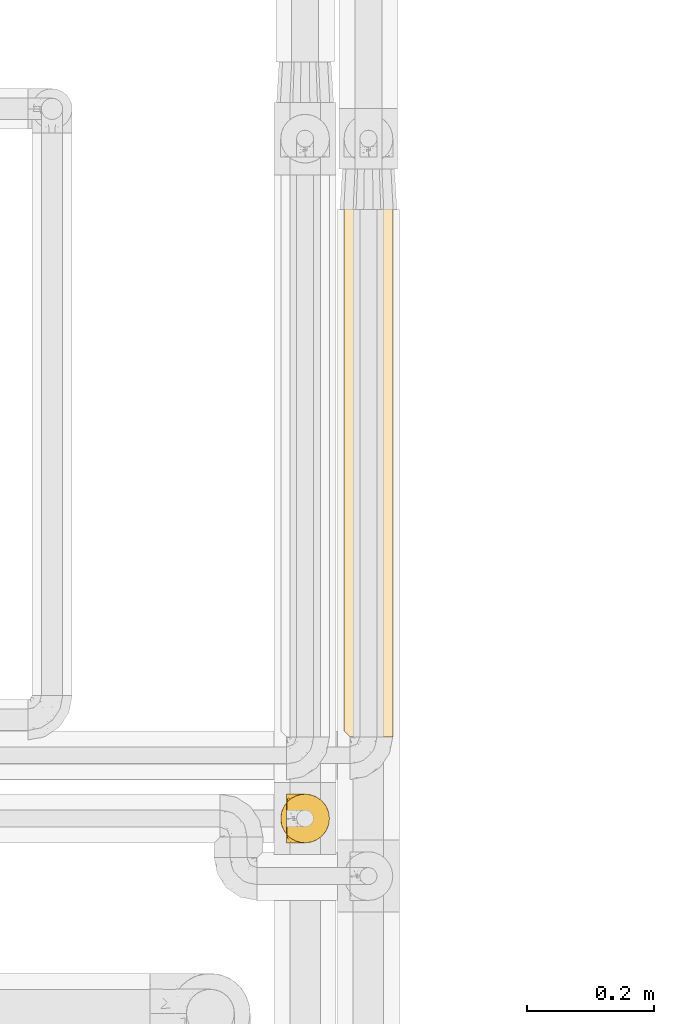
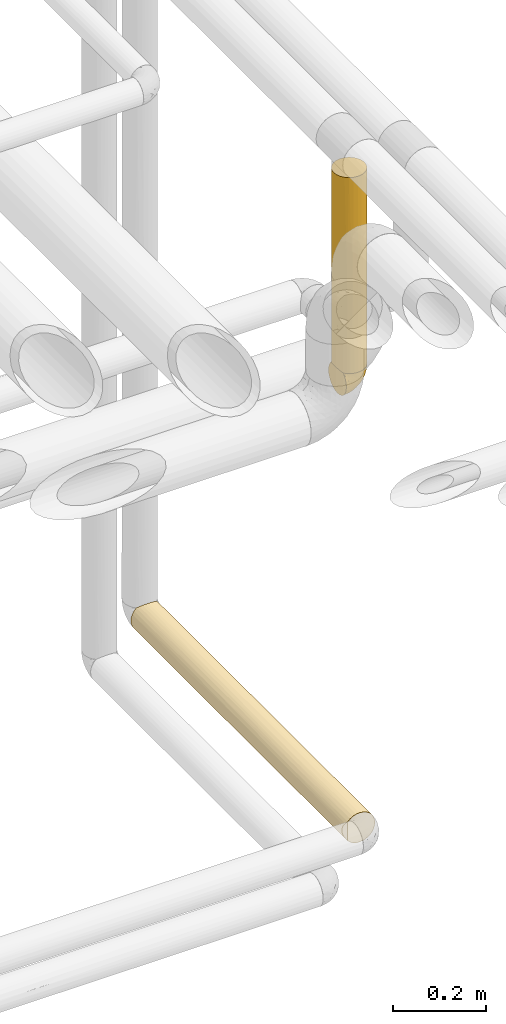
# One storey, part 498 of 827: 3 coverings.
"""IFC2X3 building model written with IfcOpenShell, lengths in millimetres."""

from ifc_helpers import new_model, entity, si_unit, converted_unit, derived_unit, direction, frame, origin, place, context, subcontext, project, spatial, faceted_brep, element, save


model = new_model("IFC2X3")

# Units and contexts
model_context = context("Model", 3, precision=0.01, world=origin(), true_north=direction((6.12303176911189e-17, 1.0)))
body_context = subcontext(model_context, "Body", "Model", "MODEL_VIEW")
ifc_project = project(units=[si_unit("LENGTHUNIT", "METRE", prefix="MILLI"), si_unit("AREAUNIT", "SQUARE_METRE"), si_unit("VOLUMEUNIT", "CUBIC_METRE"), converted_unit("PLANEANGLEUNIT", "DEGREE", entity("IfcRatioMeasure", 0.0174532925199433), si_unit("PLANEANGLEUNIT", "RADIAN"), dimensions=[0, 0, 0, 0, 0, 0, 0]), si_unit("MASSUNIT", "GRAM", prefix="KILO"), derived_unit("MASSDENSITYUNIT", [(si_unit("MASSUNIT", "GRAM", prefix="KILO"), 1), (si_unit("LENGTHUNIT", "METRE"), -3)]), derived_unit("MOMENTOFINERTIAUNIT", [(si_unit("LENGTHUNIT", "METRE"), 4)]), si_unit("TIMEUNIT", "SECOND"), si_unit("FREQUENCYUNIT", "HERTZ"), si_unit("THERMODYNAMICTEMPERATUREUNIT", "DEGREE_CELSIUS"), derived_unit("THERMALTRANSMITTANCEUNIT", [(si_unit("MASSUNIT", "GRAM", prefix="KILO"), 1), (si_unit("THERMODYNAMICTEMPERATUREUNIT", "KELVIN"), -1), (si_unit("TIMEUNIT", "SECOND"), -3)]), derived_unit("VOLUMETRICFLOWRATEUNIT", [(si_unit("LENGTHUNIT", "METRE"), 3), (si_unit("TIMEUNIT", "SECOND"), -1)]), derived_unit("MASSFLOWRATEUNIT", [(si_unit("MASSUNIT", "GRAM", prefix="KILO"), 1), (si_unit("TIMEUNIT", "SECOND"), -1)]), derived_unit("ROTATIONALFREQUENCYUNIT", [(si_unit("TIMEUNIT", "SECOND"), -1)]), si_unit("ELECTRICCURRENTUNIT", "AMPERE"), si_unit("ELECTRICVOLTAGEUNIT", "VOLT"), si_unit("POWERUNIT", "WATT"), si_unit("FORCEUNIT", "NEWTON", prefix="KILO"), si_unit("ILLUMINANCEUNIT", "LUX"), si_unit("LUMINOUSFLUXUNIT", "LUMEN"), si_unit("LUMINOUSINTENSITYUNIT", "CANDELA"), derived_unit("USERDEFINED", [(si_unit("MASSUNIT", "GRAM", prefix="KILO"), -1), (si_unit("LENGTHUNIT", "METRE"), -2), (si_unit("TIMEUNIT", "SECOND"), 3), (si_unit("LUMINOUSFLUXUNIT", "LUMEN"), 1)]), derived_unit("LINEARVELOCITYUNIT", [(si_unit("LENGTHUNIT", "METRE"), 1), (si_unit("TIMEUNIT", "SECOND"), -1)]), si_unit("PRESSUREUNIT", "PASCAL"), derived_unit("USERDEFINED", [(si_unit("LENGTHUNIT", "METRE"), -2), (si_unit("MASSUNIT", "GRAM", prefix="KILO"), 1), (si_unit("TIMEUNIT", "SECOND"), -2)]), derived_unit("LINEARFORCEUNIT", [(si_unit("MASSUNIT", "GRAM", prefix="KILO"), 1), (si_unit("LENGTHUNIT", "METRE"), 1), (si_unit("TIMEUNIT", "SECOND"), -2), (si_unit("LENGTHUNIT", "METRE"), -1)]), derived_unit("PLANARFORCEUNIT", [(si_unit("MASSUNIT", "GRAM", prefix="KILO"), 1), (si_unit("LENGTHUNIT", "METRE"), 1), (si_unit("TIMEUNIT", "SECOND"), -2), (si_unit("LENGTHUNIT", "METRE"), -2)])], contexts=[model_context])

# Site, building, storey
site_placement = place(None, origin())
site = spatial("IfcSite", under=ifc_project, at=site_placement, CompositionType="ELEMENT")
building_placement = place(site_placement, origin())
building = spatial("IfcBuilding", under=site, at=building_placement, CompositionType="ELEMENT")
storey_placement = place(building_placement, frame((0.0, 0.0, 28200.0)))
storey = spatial("IfcBuildingStorey", under=building, at=storey_placement, Name="08", CompositionType="ELEMENT", Elevation=28200.0)

# Coverings
covering_1_placement = place(storey_placement, frame((61012.64, 16339.84, 2427.5)))
element("IfcCovering", 1, at=covering_1_placement, inside=storey, Name=":ADSK_", ObjectType=":ADSK_", PredefinedType="INSULATION", context=body_context, shape_type="Brep", body=[
    faceted_brep([(77.09, 30.06, 515.24), (78.4, 40.0, 515.24), (77.09, 49.93, 515.24), (73.25, 59.2, 515.24), (67.15, 67.15, 515.24), (59.2, 73.25, 515.24), (49.93, 77.09, 515.24), (40.0, 78.4, 515.24), (30.06, 77.09, 515.24), (20.8, 73.25, 515.24), (12.84, 67.15, 515.24), (6.74, 59.2, 515.24), (2.9, 49.93, 515.24), (1.6, 40.0, 515.24), (2.9, 30.06, 515.24), (6.74, 20.8, 515.24), (12.84, 12.84, 515.24), (20.8, 6.74, 515.24), (30.06, 2.9, 515.24), (40.0, 1.6, 515.24), (49.93, 2.9, 515.24), (59.2, 6.74, 515.24), (67.15, 12.84, 515.24), (73.25, 20.8, 515.24), (77.09, 49.93, 1.6), (78.4, 40.0, 1.6), (77.09, 30.06, 1.6), (73.25, 20.8, 1.6), (67.15, 12.84, 1.6), (59.2, 6.74, 1.6), (49.93, 2.9, 1.6), (40.0, 1.6, 1.6), (31.77, 2.49, 1.6), (23.94, 5.11, 1.6), (16.85, 9.36, 1.6), (10.83, 15.02, 1.6), (10.83, 64.97, 1.6), (16.85, 70.63, 1.6), (23.94, 74.88, 1.6), (31.77, 77.5, 1.6), (40.0, 78.4, 1.6), (49.93, 77.09, 1.6), (59.2, 73.25, 1.6), (67.15, 67.15, 1.6), (73.25, 59.2, 1.6), (63.37, 9.53, 252.55), (54.69, 4.52, 258.42), (47.49, 2.33, 211.7), (75.47, 25.3, 258.42), (40.0, 1.6, 258.42), (40.0, 1.6, 217.97), (70.46, 16.62, 264.28), (77.66, 32.5, 305.13), (78.4, 40.0, 258.42), (78.4, 40.0, 298.87), (77.64, 47.56, 307.34), (75.47, 54.69, 264.28), (47.49, 77.66, 305.13), (54.69, 75.47, 258.42), (70.46, 63.37, 258.42), (63.37, 70.46, 264.28), (40.0, 78.4, 217.97), (40.0, 78.4, 258.42), (27.78, 76.4, 249.14), (16.62, 70.46, 278.77), (1.6, 40.0, 227.2), (2.96, 50.15, 252.84), (2.2, 46.76, 10.23), (5.33, 56.51, 325.54), (8.84, 62.45, 262.16), (3.98, 53.31, 8.45), (1.6, 40.0, 10.83), (6.89, 59.45, 5.54), (3.98, 26.68, 8.45), (6.89, 20.54, 5.54), (5.38, 23.38, 191.86), (8.84, 17.55, 262.16), (2.96, 29.84, 252.84), (2.2, 33.23, 10.23), (16.62, 9.53, 278.77), (27.78, 3.59, 249.14)], [[[0, 1, 2, 3, 4, 5, 6, 7, 8, 9, 10, 11, 12, 13, 14, 15, 16, 17, 18, 19, 20, 21, 22, 23]], [[24, 25, 26, 27, 28, 29, 30, 31, 32, 33, 34, 35, 36, 37, 38, 39, 40, 41, 42, 43, 44]], [[29, 28, 45]], [[20, 46, 21]], [[30, 29, 46]], [[47, 30, 46]], [[23, 48, 0]], [[47, 19, 49, 50, 31]], [[21, 45, 22]], [[30, 47, 31]], [[46, 45, 21]], [[28, 27, 51]], [[45, 46, 29]], [[52, 1, 0]], [[48, 27, 26]], [[20, 47, 46]], [[52, 25, 53, 54, 1]], [[51, 48, 23]], [[51, 27, 48]], [[22, 45, 51]], [[22, 51, 23]], [[48, 52, 0]], [[52, 26, 25]], [[51, 45, 28]], [[26, 52, 48]], [[47, 20, 19]], [[55, 24, 56]], [[41, 57, 58]], [[55, 1, 54, 53, 25]], [[56, 59, 3]], [[59, 56, 44]], [[55, 25, 24]], [[43, 59, 44]], [[59, 4, 3]], [[3, 2, 56]], [[42, 58, 60]], [[7, 57, 40, 61, 62]], [[58, 42, 41]], [[58, 5, 60]], [[43, 60, 59]], [[4, 59, 60]], [[42, 60, 43]], [[55, 56, 2]], [[5, 4, 60]], [[58, 57, 6]], [[5, 58, 6]], [[44, 56, 24]], [[57, 41, 40]], [[1, 55, 2]], [[57, 7, 6]], [[61, 39, 63]], [[38, 37, 64]], [[64, 63, 38]], [[65, 66, 67]], [[39, 61, 40]], [[63, 39, 38]], [[63, 9, 8]], [[64, 10, 9]], [[12, 11, 68]], [[69, 64, 36]], [[68, 70, 66]], [[69, 10, 64]], [[67, 66, 70]], [[11, 10, 69]], [[67, 71, 65]], [[68, 72, 70]], [[61, 63, 8]], [[68, 11, 69]], [[64, 37, 36]], [[13, 12, 66]], [[66, 65, 13]], [[63, 64, 9]], [[72, 68, 69]], [[72, 69, 36]], [[12, 68, 66]], [[8, 7, 62, 61]], [[73, 74, 75]], [[16, 15, 76]], [[35, 76, 74]], [[77, 78, 73]], [[79, 35, 34]], [[76, 75, 74]], [[65, 78, 77]], [[77, 14, 13]], [[78, 65, 71]], [[75, 15, 77]], [[65, 77, 13]], [[77, 15, 14]], [[33, 80, 79]], [[33, 32, 80]], [[15, 75, 76]], [[73, 75, 77]], [[18, 50, 49, 19]], [[32, 31, 50]], [[16, 79, 17]], [[76, 79, 16]], [[17, 79, 80]], [[50, 80, 32]], [[17, 80, 18]], [[79, 34, 33]], [[35, 79, 76]], [[50, 18, 80]], [[71, 67, 70, 72, 36, 35, 74, 73, 78]]]),
])
covering_2_placement = place(storey_placement, frame((61021.94, 16339.79, 2359.95)))
element("IfcCovering", 2, at=covering_2_placement, inside=storey, Name=":ADSK_", ObjectType=":ADSK_", PredefinedType="INSULATION", context=body_context, shape_type="Brep", body=[
    faceted_brep([(1.6, 74.68, 23.36), (1.6, 70.1, 16.07), (1.6, 64.01, 9.98), (1.6, 56.72, 5.4), (1.6, 48.6, 2.56), (1.6, 40.05, 1.6), (1.6, 31.49, 2.56), (1.6, 23.36, 5.41), (1.6, 16.07, 9.99), (1.6, 9.98, 16.08), (1.6, 5.4, 23.37), (1.6, 2.56, 31.49), (1.6, 1.6, 40.05), (1.6, 2.46, 48.15), (1.6, 5.01, 55.88), (1.6, 9.13, 62.9), (1.6, 14.62, 68.89), (1.6, 16.82, 68.89), (1.6, 18.56, 68.89), (1.6, 20.52, 68.89), (1.6, 22.49, 68.89), (1.6, 24.46, 68.89), (1.6, 26.42, 68.89), (1.6, 28.39, 68.89), (1.6, 30.36, 68.89), (1.6, 32.55, 68.89), (1.6, 34.75, 68.89), (1.6, 36.94, 68.89), (1.6, 39.13, 68.89), (1.6, 41.33, 68.89), (1.6, 43.52, 68.89), (1.6, 45.72, 68.89), (1.6, 47.91, 68.89), (1.6, 50.11, 68.89), (1.6, 52.3, 68.89), (1.6, 54.49, 68.89), (1.6, 56.69, 68.89), (1.6, 58.88, 68.89), (1.6, 61.08, 68.89), (1.6, 63.27, 68.89), (1.6, 65.47, 68.89), (1.6, 70.97, 62.89), (1.6, 75.09, 55.86), (1.6, 77.64, 48.13), (1.6, 78.5, 40.05), (1.6, 77.53, 31.49), (1.85, 14.62, 69.15), (7.85, 9.12, 69.15), (14.87, 5.0, 69.15), (22.6, 2.46, 69.15), (30.7, 1.6, 69.15), (40.65, 2.91, 69.15), (49.92, 6.75, 69.15), (57.88, 12.86, 69.15), (63.99, 20.82, 69.15), (67.84, 30.09, 69.15), (69.15, 40.05, 69.15), (67.84, 50.0, 69.15), (63.99, 59.27, 69.15), (57.88, 67.23, 69.15), (49.92, 73.34, 69.15), (40.65, 77.19, 69.15), (30.7, 78.5, 69.15), (22.6, 77.63, 69.15), (14.87, 75.09, 69.15), (7.85, 70.97, 69.15), (1.85, 65.47, 69.15), (1.85, 63.27, 69.15), (1.85, 62.29, 69.15), (1.85, 60.7, 69.15), (1.85, 59.11, 69.15), (1.85, 57.52, 69.15), (1.85, 55.93, 69.15), (1.85, 54.34, 69.15), (1.85, 52.76, 69.15), (1.85, 51.17, 69.15), (1.85, 49.58, 69.15), (1.85, 47.99, 69.15), (1.85, 46.4, 69.15), (1.85, 44.81, 69.15), (1.85, 43.22, 69.15), (1.85, 41.63, 69.15), (1.85, 40.05, 69.15), (1.85, 38.46, 69.15), (1.85, 36.87, 69.15), (1.85, 35.28, 69.15), (1.85, 33.69, 69.15), (1.85, 32.1, 69.15), (1.85, 30.51, 69.15), (1.85, 28.92, 69.15), (1.85, 27.33, 69.15), (1.85, 25.37, 69.15), (1.85, 23.4, 69.15), (1.85, 21.21, 69.15), (1.85, 19.01, 69.15), (1.85, 16.82, 69.15), (1.77, 42.32, 68.96), (1.78, 44.02, 68.97), (1.77, 47.13, 68.97), (1.77, 48.74, 68.97), (1.76, 23.57, 68.95), (1.77, 25.13, 68.96), (1.79, 61.34, 68.98), (1.78, 22.02, 68.97), (1.78, 29.72, 68.97), (1.78, 56.73, 68.98), (1.78, 55.14, 68.97), (1.78, 37.66, 68.97), (1.74, 64.12, 68.94), (1.78, 28.13, 68.98), (1.78, 26.62, 68.98), (1.77, 31.46, 68.96), (1.78, 16.16, 68.97), (1.78, 39.16, 68.98), (1.78, 50.37, 68.98), (1.77, 17.69, 68.97), (1.77, 19.17, 68.96), (1.77, 62.78, 68.97), (1.78, 58.35, 68.97), (1.78, 45.53, 68.98), (1.77, 59.91, 68.96), (1.77, 65.47, 68.97), (1.72, 65.47, 68.94), (1.77, 14.62, 68.97), (1.8, 14.62, 69.02), (1.82, 14.62, 69.08), (1.79, 20.59, 68.98), (1.78, 32.99, 68.97), (1.79, 34.48, 68.98), (1.78, 51.91, 68.97), (1.82, 65.47, 69.08), (1.8, 65.47, 69.02), (1.76, 53.48, 68.96), (1.66, 14.62, 68.92), (1.72, 14.62, 68.94), (1.78, 40.77, 68.97), (1.77, 35.97, 68.96), (9.41, 7.84, 67.02), (17.65, 3.53, 63.33), (7.41, 8.32, 64.61), (21.47, 1.6, 49.27), (15.21, 2.19, 51.4), (16.15, 1.6, 43.94), (28.75, 1.6, 61.87), (13.67, 4.57, 61.54), (12.79, 3.96, 57.95), (19.18, 2.28, 56.12), (29.16, 1.6, 63.4), (9.04, 7.69, 65.41), (7.41, 3.53, 53.1), (5.74, 8.32, 63.04), (3.72, 7.84, 61.33), (8.87, 1.6, 41.99), (26.8, 1.6, 54.6), (9.53, 4.34, 56.6), (7.34, 1.6, 41.58), (37.63, 29.63, 13.72), (17.92, 27.34, 5.82), (27.45, 40.05, 6.74), (37.01, 2.39, 58.82), (34.22, 2.43, 51.58), (45.87, 9.07, 42.09), (56.57, 16.64, 46.12), (52.31, 9.54, 55.56), (42.07, 4.52, 52.38), (44.74, 4.52, 61.54), (21.49, 7.49, 23.76), (11.02, 7.49, 20.5), (15.64, 12.85, 14.64), (26.02, 2.35, 41.77), (36.59, 22.66, 16.28), (65.49, 32.9, 49.4), (63.99, 25.33, 52.34), (15.2, 40.05, 4.3), (60.27, 16.64, 58.67), (45.25, 19.99, 25.26), (35.21, 16.37, 20.17), (22.52, 3.26, 34.7), (12.03, 3.75, 28.67), (13.32, 19.58, 8.62), (35.9, 7.5, 33.37), (33.87, 4.04, 41.35), (25.73, 13.94, 17.15), (26.34, 19.58, 12.68), (46.78, 28.21, 21.47), (59.54, 24.75, 41.11), (60.18, 31.42, 37.53), (53.93, 26.2, 30.64), (53.36, 33.36, 26.66), (49.36, 40.05, 21.38), (38.4, 40.05, 14.06), (66.44, 40.05, 55.54), (50.09, 16.14, 35.17), (41.08, 12.85, 29.04), (31.14, 10.47, 24.34), (28.19, 6.49, 29.33), (64.0, 40.05, 43.3), (56.68, 40.05, 32.34), (43.9, 75.57, 57.75), (65.46, 47.37, 49.41), (52.22, 52.91, 27.85), (37.61, 50.46, 13.7), (15.64, 67.23, 14.63), (13.31, 60.5, 8.61), (50.02, 70.55, 48.85), (59.28, 63.45, 54.13), (53.05, 62.61, 37.84), (21.48, 72.6, 23.75), (11.01, 72.6, 20.49), (12.03, 76.34, 28.66), (41.02, 59.34, 20.83), (35.39, 77.76, 55.15), (26.8, 78.5, 54.6), (28.75, 78.5, 61.87), (7.34, 78.5, 41.58), (65.81, 53.16, 57.58), (53.28, 70.55, 59.91), (59.8, 48.88, 36.94), (61.82, 54.76, 45.72), (17.91, 52.74, 5.82), (41.4, 71.93, 37.91), (40.48, 75.79, 50.18), (26.34, 60.5, 12.67), (31.68, 77.86, 49.29), (27.68, 77.64, 42.64), (16.15, 78.5, 43.94), (21.47, 78.5, 49.27), (28.05, 67.23, 19.45), (22.54, 76.82, 34.7), (8.87, 78.5, 41.99), (37.3, 77.8, 62.29), (41.07, 67.23, 29.01), (32.24, 73.2, 31.47), (47.4, 67.66, 37.18), (35.77, 75.99, 43.45), (17.65, 76.57, 63.33), (11.06, 73.21, 67.23), (8.55, 71.93, 66.07), (6.63, 71.07, 65.22), (12.77, 75.09, 61.99), (12.79, 76.13, 57.95), (7.41, 76.57, 53.09), (18.97, 77.69, 56.84), (1.66, 65.47, 68.92), (3.72, 72.26, 61.33), (5.76, 71.77, 63.06), (15.21, 77.9, 51.41), (9.52, 75.75, 56.61)], [[[0, 1, 2, 3, 4, 5, 6, 7, 8, 9, 10, 11, 12, 13, 14, 15, 16, 17, 18, 19, 20, 21, 22, 23, 24, 25, 26, 27, 28, 29, 30, 31, 32, 33, 34, 35, 36, 37, 38, 39, 40, 41, 42, 43, 44, 45]], [[46, 47, 48, 49, 50, 51, 52, 53, 54, 55, 56, 57, 58, 59, 60, 61, 62, 63, 64, 65, 66, 67, 68, 69, 70, 71, 72, 73, 74, 75, 76, 77, 78, 79, 80, 81, 82, 83, 84, 85, 86, 87, 88, 89, 90, 91, 92, 93, 94, 95]], [[96, 97, 30]], [[98, 77, 99]], [[100, 101, 21]], [[69, 68, 102]], [[20, 19, 103]], [[24, 23, 104]], [[20, 103, 100]], [[72, 105, 106]], [[84, 83, 107]], [[89, 88, 104]], [[108, 67, 66]], [[109, 110, 90]], [[111, 25, 24]], [[112, 17, 16]], [[82, 113, 83]], [[109, 23, 22]], [[114, 76, 75]], [[105, 36, 106]], [[104, 111, 24]], [[18, 115, 116]], [[97, 96, 80]], [[67, 108, 117]], [[105, 71, 118]], [[31, 97, 119]], [[102, 120, 69]], [[108, 121, 122]], [[112, 95, 115]], [[17, 115, 18]], [[94, 116, 115]], [[117, 68, 67]], [[38, 117, 39]], [[112, 123, 124, 125, 46]], [[17, 112, 115]], [[70, 120, 118]], [[39, 117, 108]], [[120, 38, 37]], [[120, 37, 118]], [[120, 70, 69]], [[116, 94, 126]], [[127, 86, 128]], [[117, 38, 102]], [[74, 129, 75]], [[99, 33, 32]], [[115, 95, 94]], [[39, 108, 40]], [[108, 66, 130, 131, 121]], [[105, 72, 71]], [[118, 37, 36]], [[71, 70, 118]], [[35, 106, 36]], [[36, 105, 118]], [[35, 132, 106]], [[74, 73, 132]], [[106, 132, 73]], [[99, 114, 33]], [[132, 35, 34]], [[73, 72, 106]], [[95, 112, 46]], [[112, 16, 133, 134]], [[129, 114, 75]], [[99, 76, 114]], [[114, 129, 33]], [[34, 33, 129]], [[78, 77, 98]], [[98, 119, 78]], [[129, 132, 34]], [[132, 129, 74]], [[79, 97, 80]], [[98, 99, 32]], [[98, 32, 31]], [[77, 76, 99]], [[97, 79, 119]], [[135, 96, 29]], [[30, 97, 31]], [[135, 29, 28]], [[81, 80, 96]], [[29, 96, 30]], [[31, 119, 98]], [[119, 79, 78]], [[96, 135, 81]], [[82, 81, 135]], [[113, 107, 83]], [[84, 107, 136]], [[107, 27, 136]], [[113, 28, 107]], [[27, 107, 28]], [[85, 84, 136]], [[136, 27, 26]], [[113, 135, 28]], [[135, 113, 82]], [[109, 89, 104]], [[86, 85, 128]], [[89, 109, 90]], [[111, 87, 127]], [[26, 128, 136]], [[88, 111, 104]], [[25, 111, 127]], [[22, 110, 109]], [[23, 109, 104]], [[110, 91, 90]], [[100, 92, 101]], [[110, 22, 101]], [[91, 110, 101]], [[116, 19, 18]], [[111, 88, 87]], [[126, 103, 19]], [[25, 127, 26]], [[86, 127, 87]], [[127, 128, 26]], [[136, 128, 85]], [[120, 102, 38]], [[117, 102, 68]], [[91, 101, 92]], [[21, 101, 22]], [[93, 92, 103]], [[100, 21, 20]], [[100, 103, 92]], [[126, 93, 103]], [[93, 126, 94]], [[116, 126, 19]], [[125, 137, 47]], [[48, 137, 138]], [[139, 124, 123]], [[140, 141, 142]], [[143, 49, 138]], [[144, 139, 145]], [[48, 138, 49]], [[138, 144, 146]], [[49, 143, 147, 50]], [[125, 124, 148]], [[14, 13, 149]], [[150, 145, 139]], [[148, 139, 144]], [[151, 150, 134]], [[151, 14, 149]], [[16, 15, 133]], [[13, 152, 149]], [[123, 150, 139]], [[140, 146, 141]], [[14, 151, 15]], [[15, 151, 133]], [[47, 46, 125]], [[138, 153, 143]], [[137, 48, 47]], [[124, 139, 148]], [[134, 133, 151]], [[145, 154, 141]], [[144, 145, 146]], [[148, 138, 137]], [[146, 140, 153]], [[146, 145, 141]], [[138, 146, 153]], [[138, 148, 144]], [[148, 137, 125]], [[154, 145, 150]], [[149, 142, 141]], [[151, 154, 150]], [[149, 141, 154]], [[13, 12, 155, 152]], [[152, 142, 149]], [[151, 149, 154]], [[150, 123, 134]], [[156, 157, 158]], [[159, 153, 160]], [[161, 162, 163]], [[164, 165, 159]], [[166, 167, 168]], [[140, 169, 160]], [[155, 12, 11]], [[157, 156, 170]], [[171, 55, 172]], [[157, 6, 173]], [[174, 54, 53]], [[52, 165, 163]], [[52, 163, 53]], [[54, 174, 172]], [[165, 52, 51]], [[175, 176, 170]], [[177, 142, 178]], [[155, 11, 178]], [[8, 7, 179]], [[168, 9, 8]], [[178, 142, 152, 155]], [[178, 11, 10]], [[167, 178, 10]], [[180, 161, 181]], [[178, 166, 177]], [[182, 183, 176]], [[182, 168, 183]], [[175, 170, 184]], [[171, 185, 186]], [[157, 7, 6]], [[158, 157, 173]], [[183, 179, 157]], [[54, 172, 55]], [[179, 168, 8]], [[187, 188, 186]], [[9, 167, 10]], [[185, 187, 186]], [[189, 156, 158, 190]], [[55, 171, 191]], [[175, 192, 193]], [[160, 169, 181]], [[161, 163, 164]], [[174, 163, 162]], [[51, 50, 147]], [[166, 194, 195]], [[177, 181, 169]], [[6, 5, 173]], [[157, 179, 7]], [[168, 179, 183]], [[168, 167, 9]], [[178, 167, 166]], [[181, 161, 164]], [[161, 193, 192]], [[160, 164, 159]], [[194, 180, 195]], [[191, 171, 196]], [[191, 56, 55]], [[188, 189, 197]], [[197, 196, 186]], [[171, 186, 196]], [[184, 188, 187]], [[197, 186, 188]], [[185, 171, 172]], [[172, 162, 185]], [[192, 185, 162]], [[175, 184, 187]], [[184, 156, 189]], [[187, 185, 192]], [[176, 175, 193]], [[187, 192, 175]], [[161, 192, 162]], [[194, 176, 193]], [[170, 176, 183]], [[180, 194, 193]], [[182, 166, 168]], [[161, 180, 193]], [[195, 181, 177]], [[157, 170, 183]], [[170, 156, 184]], [[176, 194, 182]], [[166, 182, 194]], [[181, 195, 180]], [[177, 169, 142]], [[177, 166, 195]], [[163, 174, 53]], [[172, 174, 162]], [[159, 51, 147]], [[163, 165, 164]], [[51, 159, 165]], [[159, 147, 143, 153]], [[140, 160, 153]], [[181, 164, 160]], [[189, 188, 184]], [[142, 169, 140]], [[60, 198, 61]], [[196, 199, 191]], [[200, 189, 201]], [[199, 57, 191]], [[202, 203, 2]], [[204, 205, 206]], [[207, 208, 209]], [[210, 206, 200]], [[211, 212, 213]], [[45, 214, 209]], [[215, 205, 58]], [[45, 44, 214]], [[59, 216, 60]], [[60, 216, 198]], [[0, 45, 209]], [[217, 200, 218]], [[201, 158, 219]], [[204, 220, 221]], [[222, 203, 202]], [[1, 202, 2]], [[57, 199, 215]], [[219, 3, 203]], [[219, 173, 4]], [[1, 0, 208]], [[211, 223, 212]], [[224, 225, 226]], [[227, 222, 202]], [[207, 209, 228]], [[209, 225, 228]], [[3, 219, 4]], [[58, 205, 59]], [[208, 202, 1]], [[201, 219, 222]], [[227, 202, 207]], [[201, 210, 200]], [[3, 2, 203]], [[201, 189, 190, 158]], [[209, 214, 229, 225]], [[198, 211, 230]], [[231, 232, 220]], [[232, 207, 228]], [[206, 205, 218]], [[216, 205, 204]], [[226, 223, 224]], [[232, 231, 227]], [[200, 206, 218]], [[233, 231, 220]], [[217, 218, 199]], [[201, 222, 210]], [[173, 219, 158]], [[173, 5, 4]], [[61, 230, 62]], [[219, 203, 222]], [[209, 208, 0]], [[202, 208, 207]], [[224, 232, 228]], [[223, 226, 212]], [[220, 232, 234]], [[57, 56, 191]], [[197, 217, 196]], [[199, 218, 215]], [[200, 197, 189]], [[196, 217, 199]], [[197, 200, 217]], [[205, 215, 218]], [[58, 57, 215]], [[230, 211, 213]], [[221, 211, 198]], [[227, 210, 222]], [[206, 210, 231]], [[62, 230, 213]], [[198, 230, 61]], [[232, 227, 207]], [[210, 227, 231]], [[221, 220, 234]], [[233, 204, 206]], [[205, 216, 59]], [[198, 216, 204]], [[204, 221, 198]], [[223, 221, 234]], [[221, 223, 211]], [[223, 234, 224]], [[232, 224, 234]], [[225, 224, 228]], [[204, 233, 220]], [[206, 231, 233]], [[63, 213, 235]], [[213, 212, 235]], [[213, 63, 62]], [[236, 235, 237]], [[237, 131, 130]], [[235, 236, 64]], [[238, 239, 240]], [[63, 235, 64]], [[130, 66, 65]], [[236, 130, 65]], [[241, 229, 43]], [[236, 65, 64]], [[238, 121, 131]], [[42, 241, 43]], [[240, 239, 242]], [[41, 243, 244]], [[43, 229, 214, 44]], [[244, 122, 245]], [[226, 246, 242]], [[240, 247, 245]], [[121, 238, 245]], [[41, 40, 243]], [[131, 237, 238]], [[244, 42, 41]], [[130, 236, 237]], [[239, 238, 237]], [[245, 238, 240]], [[247, 240, 246]], [[247, 244, 245]], [[237, 235, 239]], [[242, 235, 212]], [[235, 242, 239]], [[226, 225, 246]], [[242, 212, 226]], [[241, 246, 225]], [[242, 246, 240]], [[246, 241, 247]], [[244, 247, 241]], [[241, 225, 229]], [[42, 244, 241]], [[122, 244, 243]], [[122, 121, 245]], [[108, 122, 243, 40]], [[112, 134, 123]]]),
])
covering_3_placement = place(storey_placement, frame((61112.64, 16507.16, 1060.0)))
element("IfcCovering", 3, at=covering_3_placement, inside=storey, Name=":ADSK_", ObjectType=":ADSK_", PredefinedType="INSULATION", context=body_context, shape_type="Brep", body=[
    faceted_brep([(5.09, 916.58, 56.01), (9.31, 916.58, 63.08), (14.94, 916.58, 69.1), (65.05, 916.58, 69.1), (70.68, 916.58, 63.08), (74.9, 916.58, 56.01), (77.51, 916.58, 48.2), (78.4, 916.58, 40.0), (77.09, 916.58, 30.06), (73.25, 916.58, 20.8), (67.15, 916.58, 12.84), (59.2, 916.58, 6.74), (49.93, 916.58, 2.9), (40.0, 916.58, 1.6), (30.06, 916.58, 2.9), (20.8, 916.58, 6.74), (12.84, 916.58, 12.84), (6.74, 916.58, 20.8), (2.9, 916.58, 30.06), (1.6, 916.58, 40.0), (2.48, 916.58, 48.2), (67.15, 1.6, 67.15), (59.2, 1.6, 73.25), (49.93, 1.6, 77.09), (40.0, 1.6, 78.4), (31.79, 1.6, 77.51), (23.98, 1.6, 74.9), (16.91, 1.6, 70.68), (10.9, 1.6, 65.05), (10.9, 1.6, 14.94), (16.91, 1.6, 9.31), (23.98, 1.6, 5.09), (31.79, 1.6, 2.48), (40.0, 1.6, 1.6), (49.93, 1.6, 2.9), (59.2, 1.6, 6.74), (67.15, 1.6, 12.84), (73.25, 1.6, 20.8), (77.09, 1.6, 30.06), (78.4, 1.6, 40.0), (77.09, 1.6, 49.93), (73.25, 1.6, 59.2), (70.46, 207.41, 16.62), (78.4, 700.2, 40.0), (78.4, 217.97, 40.0), (74.01, 333.25, 22.17), (76.93, 326.15, 29.5), (40.0, 217.97, 1.6), (40.0, 700.2, 1.6), (52.55, 711.25, 3.71), (46.97, 567.56, 2.23), (78.4, 434.34, 40.0), (47.39, 326.15, 2.31), (54.69, 230.52, 4.52), (75.47, 625.24, 25.3), (63.37, 633.19, 9.53), (54.69, 501.42, 4.52), (77.76, 567.27, 33.07), (78.4, 483.83, 40.0), (63.37, 299.14, 9.53), (70.46, 459.09, 16.62), (70.46, 710.76, 16.62), (40.0, 434.34, 1.6), (40.0, 675.46, 1.6), (20.33, 200.53, 7.01), (27.82, 266.17, 3.58), (5.66, 346.08, 22.81), (4.52, 636.44, 25.3), (8.98, 462.38, 17.36), (29.45, 589.77, 3.07), (13.94, 338.01, 11.79), (2.2, 10.29, 33.21), (1.6, 227.27, 40.0), (2.98, 317.48, 29.79), (21.1, 673.86, 6.57), (20.33, 432.28, 7.01), (14.43, 619.9, 11.34), (8.88, 222.44, 17.5), (1.6, 443.64, 40.0), (2.24, 571.92, 32.99), (4.0, 8.5, 26.63), (9.1, 706.46, 17.19), (1.6, 700.21, 40.0), (6.92, 5.57, 20.48), (1.6, 10.9, 40.0), (2.2, 10.29, 46.78), (33.21, 907.88, 77.79), (40.0, 690.9, 78.4), (40.0, 907.28, 78.4), (17.37, 463.29, 71.02), (17.5, 699.65, 71.12), (10.48, 587.03, 64.56), (3.58, 680.34, 52.17), (14.66, 235.7, 68.85), (5.42, 456.74, 56.71), (2.97, 267.41, 50.19), (5.36, 193.19, 56.58), (4.0, 8.5, 53.36), (8.89, 261.48, 62.52), (2.88, 479.69, 49.84), (20.82, 275.33, 73.26), (22.81, 577.8, 74.34), (20.48, 912.61, 73.07), (6.77, 715.61, 59.25), (6.92, 5.57, 59.51), (27.82, 292.28, 76.41), (29.79, 600.69, 77.01), (40.0, 238.06, 78.4), (40.0, 474.53, 78.4), (26.63, 909.68, 76.0), (40.0, 217.97, 78.4), (54.69, 281.74, 75.47), (62.8, 211.71, 70.89), (68.65, 298.28, 65.56), (68.2, 580.16, 66.05), (62.63, 455.79, 71.02), (47.0, 346.25, 77.75), (57.18, 572.09, 74.33), (50.2, 600.69, 77.01), (53.36, 909.68, 76.0), (46.78, 907.88, 77.79), (75.47, 248.62, 54.69), (62.49, 695.73, 71.11), (59.51, 912.61, 73.07), (77.02, 592.02, 50.18), (77.71, 350.9, 47.2), (72.98, 485.89, 59.66), (72.98, 717.64, 59.66)], [[[0, 1, 2, 3, 4, 5, 6, 7, 8, 9, 10, 11, 12, 13, 14, 15, 16, 17, 18, 19, 20]], [[21, 22, 23, 24, 25, 26, 27, 28, 29, 30, 31, 32, 33, 34, 35, 36, 37, 38, 39, 40, 41]], [[37, 36, 42]], [[8, 7, 43]], [[44, 39, 38]], [[45, 38, 37]], [[46, 44, 38]], [[34, 33, 47]], [[48, 13, 12]], [[12, 49, 50]], [[45, 37, 42]], [[46, 51, 44]], [[47, 52, 34]], [[34, 53, 35]], [[8, 54, 9]], [[11, 10, 55]], [[52, 56, 53]], [[54, 46, 45]], [[57, 43, 58, 51]], [[49, 56, 50]], [[36, 35, 59]], [[59, 55, 60, 42]], [[53, 59, 35]], [[61, 54, 60]], [[56, 49, 55]], [[9, 61, 10]], [[55, 10, 61]], [[59, 56, 55]], [[57, 46, 54]], [[43, 57, 8]], [[50, 56, 52]], [[59, 53, 56]], [[52, 47, 62]], [[50, 62, 63, 48]], [[34, 52, 53]], [[46, 57, 51]], [[8, 57, 54]], [[59, 42, 36]], [[45, 42, 60]], [[54, 45, 60]], [[45, 46, 38]], [[54, 61, 9]], [[55, 61, 60]], [[62, 50, 52]], [[12, 50, 48]], [[12, 11, 49]], [[55, 49, 11]], [[64, 65, 31]], [[66, 67, 68]], [[31, 30, 64]], [[62, 65, 69]], [[30, 29, 70]], [[71, 72, 73]], [[32, 65, 47]], [[14, 69, 74]], [[75, 70, 76]], [[75, 69, 65]], [[14, 63, 69]], [[70, 29, 77]], [[73, 78, 79]], [[80, 73, 66]], [[74, 76, 15]], [[32, 31, 65]], [[76, 81, 16]], [[73, 80, 71]], [[65, 62, 47]], [[66, 68, 77]], [[17, 81, 67]], [[77, 68, 70]], [[78, 82, 79]], [[67, 18, 17]], [[83, 80, 66]], [[76, 74, 75]], [[83, 77, 29]], [[47, 33, 32]], [[19, 18, 82]], [[76, 70, 68]], [[70, 75, 64]], [[81, 76, 68]], [[15, 76, 16]], [[70, 64, 30]], [[65, 64, 75]], [[79, 18, 67]], [[18, 79, 82]], [[73, 79, 67]], [[66, 77, 83]], [[67, 66, 73]], [[67, 81, 68]], [[16, 81, 17]], [[14, 74, 15]], [[69, 75, 74]], [[72, 71, 84]], [[72, 78, 73]], [[14, 13, 48, 63]], [[63, 62, 69]], [[84, 85, 72]], [[86, 87, 88]], [[89, 90, 91]], [[20, 92, 0]], [[93, 28, 27]], [[94, 95, 96]], [[95, 85, 97]], [[2, 91, 90]], [[98, 91, 94]], [[99, 95, 94]], [[97, 96, 95]], [[100, 89, 93]], [[20, 82, 92]], [[101, 102, 90]], [[0, 92, 103]], [[101, 90, 89]], [[104, 28, 98]], [[105, 106, 101]], [[25, 105, 26]], [[72, 85, 95]], [[106, 87, 86]], [[25, 107, 105]], [[102, 2, 90]], [[98, 96, 104]], [[108, 106, 105]], [[109, 106, 86]], [[26, 105, 100]], [[109, 102, 101]], [[98, 93, 91]], [[20, 19, 82]], [[93, 89, 91]], [[91, 2, 1]], [[72, 95, 78]], [[103, 1, 0]], [[91, 103, 94]], [[94, 92, 99]], [[99, 82, 78]], [[101, 89, 100]], [[109, 101, 106]], [[94, 103, 92]], [[1, 103, 91]], [[82, 99, 92]], [[78, 95, 99]], [[106, 108, 87]], [[28, 93, 98]], [[27, 26, 100]], [[100, 93, 27]], [[101, 100, 105]], [[104, 96, 97]], [[94, 96, 98]], [[25, 24, 110, 107]], [[107, 108, 105]], [[111, 22, 112]], [[113, 114, 115]], [[116, 108, 107, 110]], [[117, 111, 115]], [[118, 108, 116]], [[118, 119, 120]], [[22, 111, 23]], [[121, 113, 41]], [[119, 118, 117]], [[113, 112, 21]], [[120, 87, 118]], [[122, 3, 123]], [[3, 114, 4]], [[124, 121, 125]], [[123, 119, 117]], [[40, 39, 44]], [[58, 43, 124]], [[126, 113, 121]], [[126, 114, 113]], [[41, 40, 121]], [[127, 5, 4]], [[117, 115, 122]], [[6, 43, 7]], [[6, 5, 124]], [[24, 23, 110]], [[5, 127, 124]], [[122, 114, 3]], [[122, 115, 114]], [[6, 124, 43]], [[114, 126, 127]], [[112, 113, 115]], [[41, 113, 21]], [[44, 125, 40]], [[124, 126, 121]], [[125, 44, 51, 58]], [[114, 127, 4]], [[124, 127, 126]], [[116, 23, 111]], [[23, 116, 110]], [[118, 116, 111]], [[124, 125, 58]], [[40, 125, 121]], [[117, 122, 123]], [[111, 117, 118]], [[111, 112, 115]], [[21, 112, 22]], [[87, 120, 88]], [[87, 108, 118]], [[102, 109, 86, 88, 120, 119, 123, 3, 2]], [[85, 84, 71, 80, 83, 29, 28, 104, 97]]]),
])

save(model, "model.ifc")
